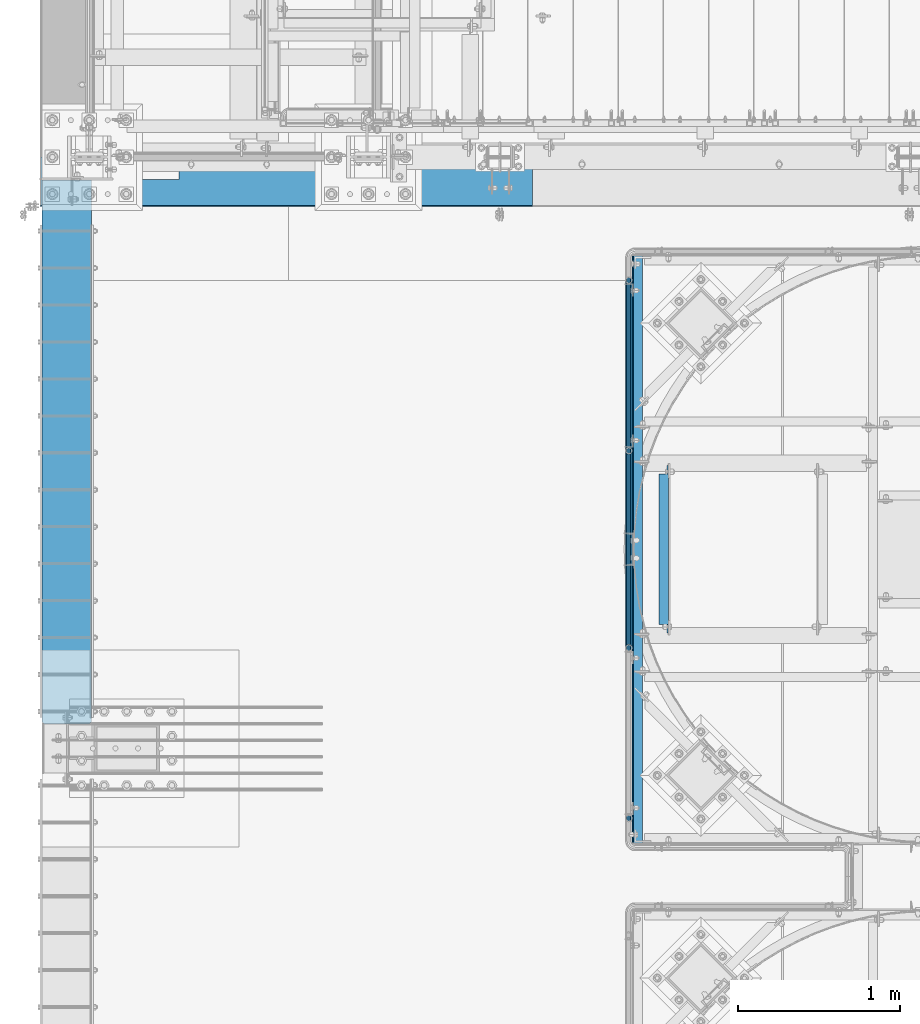
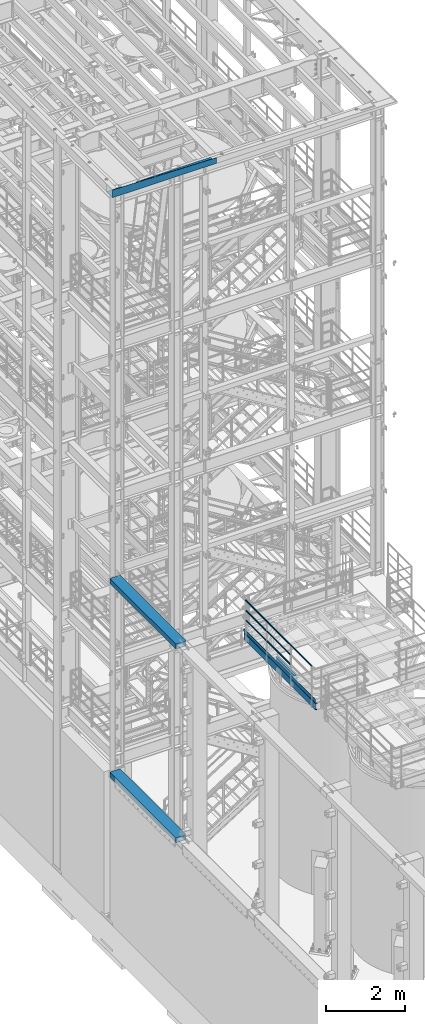
# One storey, part 929 of 1876: 11 beams, 6 elements without a shape of their own.
"""IFC2X3 building model written with IfcOpenShell, lengths in millimetres."""

import ifcopenshell
import ifcopenshell.guid

model = None  # the IFC model being written
_history = None  # IfcOwnerHistory: only IFC2X3 demands one
_inside = {}  # id of a spatial element -> (the spatial element, [elements in it])
_under = {}  # id of a project, library or spatial element -> (it, [spatial elements below it])
_declared = {}  # id of a project -> (the project, [libraries it declares])
_typed = {}  # id of a type object -> (the type object, [elements of that type])
_made_of = {}  # id of a material, layer set ... -> (it, [elements and type objects made of it])


def new_model(schema):
    """Start an empty IFC model of exactly this schema.

    Asked for "IFC4X3", IfcOpenShell would pick the latest addendum, in which some entities
    have other attributes; the version numbers below select the first issue.
    IFC2X3 requires an IfcOwnerHistory on every rooted entity: one is made here for all.
    """
    global model, _history
    if schema == "IFC4X3":
        model = ifcopenshell.file(schema_version=(4, 3, 0, 0))
    else:
        model = ifcopenshell.file(schema=schema)
    _inside.clear()
    _under.clear()
    _declared.clear()
    _typed.clear()
    _made_of.clear()
    _history = None
    if model.schema == "IFC2X3":
        org = make("IfcOrganization", Name="unknown")
        user = make(
            "IfcPersonAndOrganization",
            ThePerson=make("IfcPerson", FamilyName="unknown"),
            TheOrganization=org,
        )
        app = make(
            "IfcApplication",
            ApplicationDeveloper=org,
            Version="unknown",
            ApplicationFullName="unknown",
            ApplicationIdentifier="unknown",
        )
        _history = make(
            "IfcOwnerHistory",
            OwningUser=user,
            OwningApplication=app,
            ChangeAction="ADDED",
            CreationDate=0,
        )
    return model


def make(cls, **values):
    """One entity of the class cls with the attributes given. An attribute that is None is left unset."""
    return model.create_entity(
        cls, **{name: value for name, value in values.items() if value is not None}
    )


def rooted(cls, **values):
    """An entity with a GlobalId (a new one), such as an element, a storey or a relation."""
    return make(cls, GlobalId=ifcopenshell.guid.new(), OwnerHistory=_history, **values)


def si_unit(unit_type, name, prefix=None):
    """IfcSIUnit, for example si_unit("LENGTHUNIT", "METRE", prefix="MILLI")."""
    return make("IfcSIUnit", UnitType=unit_type, Prefix=prefix, Name=name)


def assignment(units):
    """IfcUnitAssignment: the units of a project."""
    return None if units is None else make("IfcUnitAssignment", Units=units)


def point(xyz):
    """IfcCartesianPoint."""
    return None if xyz is None else make("IfcCartesianPoint", Coordinates=xyz)


def direction(xyz):
    """IfcDirection."""
    return None if xyz is None else make("IfcDirection", DirectionRatios=xyz)


def frame(location, z_axis=None, x_axis=None):
    """IfcAxis2Placement3D, a coordinate frame: its origin and axes. An axis left out is left unset."""
    return make(
        "IfcAxis2Placement3D",
        Location=point(location),
        Axis=direction(z_axis),
        RefDirection=direction(x_axis),
    )


def origin_with_axes():
    """The frame at (0, 0, 0) with the z axis (0, 0, 1) and the x axis (1, 0, 0) written out."""
    return frame((0.0, 0.0, 0.0), z_axis=(0.0, 0.0, 1.0), x_axis=(1.0, 0.0, 0.0))


def place(relative_to, where):
    """IfcLocalPlacement: puts the frame where relative to a parent placement (None: the world)."""
    return make(
        "IfcLocalPlacement", PlacementRelTo=relative_to, RelativePlacement=where
    )


def context(
    kind, dimensions, precision=None, world=None, true_north=None, identifier=None
):
    """IfcGeometricRepresentationContext, for example the 3D "Model" context."""
    return make(
        "IfcGeometricRepresentationContext",
        ContextIdentifier=identifier,
        ContextType=kind,
        CoordinateSpaceDimension=dimensions,
        Precision=precision,
        WorldCoordinateSystem=world,
        TrueNorth=true_north,
    )


def subcontext(parent, identifier, kind, view, scale=None):
    """IfcGeometricRepresentationSubContext, for example "Body" below "Model"."""
    return make(
        "IfcGeometricRepresentationSubContext",
        ContextIdentifier=identifier,
        ContextType=kind,
        ParentContext=parent,
        TargetScale=scale,
        TargetView=view,
    )


def project(units=None, contexts=None):
    """IfcProject with its units and contexts."""
    return rooted(
        "IfcProject",
        Name="project",
        RepresentationContexts=contexts,
        UnitsInContext=assignment(units),
    )


def spatial(cls, under=None, at=None, **own):
    """A site, building, storey or space (cls), placed at a placement, below another one or the project."""
    s = rooted(cls, ObjectPlacement=at, **own)
    if under is not None:
        _under.setdefault(under.id(), (under, []))[1].append(s)
    return s


def faces_of(points, faces, orient=None, outer=None):
    """IfcFace entities. A face is a list of loops; a loop is a list of indices into points, from 0.

    orient and outer hold one flag for each loop. By default every Orientation is true, the
    first loop of a face is its IfcFaceOuterBound and the others are IfcFaceBound.
    """
    made = []
    for i, loops in enumerate(faces):
        bounds = []
        for j, loop in enumerate(loops):
            is_outer = j == 0 if outer is None else outer[i][j]
            bounds.append(
                make(
                    "IfcFaceOuterBound" if is_outer else "IfcFaceBound",
                    Bound=make("IfcPolyLoop", Polygon=[points[k] for k in loop]),
                    Orientation=True if orient is None else orient[i][j],
                )
            )
        made.append(make("IfcFace", Bounds=bounds))
    return made


def faceted_brep(points, faces, orient=None, outer=None, voids=None):
    """IfcFacetedBrep: a solid bounded by flat faces; with voids (closed shells), ...WithVoids."""
    shared = [point(p) for p in points]
    hull = make("IfcClosedShell", CfsFaces=faces_of(shared, faces, orient, outer))
    if voids is None:
        return make("IfcFacetedBrep", Outer=hull)
    return make(
        "IfcFacetedBrepWithVoids",
        Outer=hull,
        Voids=[
            make(cls, CfsFaces=faces_of(shared, fs, o, b)) for cls, fs, o, b in voids
        ],
    )


def shape(context_of_items, identifier, shape_type, items):
    """IfcShapeRepresentation: the items that make up one representation, for example the "Body"."""
    return make(
        "IfcShapeRepresentation",
        ContextOfItems=context_of_items,
        RepresentationIdentifier=identifier,
        RepresentationType=shape_type,
        Items=items,
    )


def material(Name=None, Category=None):
    """IfcMaterial."""
    return make("IfcMaterial", Name=Name, Category=Category)


def made_of(thing, what):
    """Note that an element or type object is made of a material, layer set ...; save() writes the relation."""
    if what is not None:
        _made_of.setdefault(what.id(), (what, []))[1].append(thing)
    return thing


def type_object(cls, material=None, **own):
    """A type object (cls), such as IfcWallType, which elements share."""
    return made_of(rooted(cls, **own), material)


def element(
    cls,
    number,
    at=None,
    inside=None,
    cuts=None,
    type_object=None,
    material=None,
    context=None,
    identifier="Body",
    shape_type=None,
    held_by="IfcProductDefinitionShape",
    body=None,
    shapes=None,
    **own,
):
    """One element of the class cls, such as IfcWall. Its Tag is "e" and its number.

    at: its placement. inside: the storey or other place that contains it. cuts: it is an
    opening in that element (IfcRelVoidsElement). A single representation is given by context,
    identifier, shape_type and body (its items); several are given by shapes. held_by: the class
    of the entity that holds the representations. save() writes the other relations.
    """
    e = rooted(cls, Tag="e%d" % number, ObjectPlacement=at, **own)
    if body is not None:
        shapes = [shape(context, identifier, shape_type, body)]
    if shapes is not None:
        e.Representation = make(held_by, Representations=shapes)
    if inside is not None:
        _inside.setdefault(inside.id(), (inside, []))[1].append(e)
    if cuts is not None:
        rooted(
            "IfcRelVoidsElement", RelatingBuildingElement=cuts, RelatedOpeningElement=e
        )
    if type_object is not None:
        _typed.setdefault(type_object.id(), (type_object, []))[1].append(e)
    return made_of(e, material)


def aggregate(whole, parts):
    """IfcRelAggregates: a whole, such as a stair, and the parts it consists of."""
    return rooted("IfcRelAggregates", RelatingObject=whole, RelatedObjects=parts)


def save(model, path):
    """Write the relations noted so far, then the file.

    IfcRelAggregates (storeys below a building ...), IfcRelContainedInSpatialStructure (elements
    in a storey), IfcRelDefinesByType, IfcRelAssociatesMaterial and IfcRelDeclares: one each for
    every whole, place, type object, material and project.
    """
    for whole, parts in _under.values():
        aggregate(whole, parts)
    for where, things in _inside.values():
        rooted(
            "IfcRelContainedInSpatialStructure",
            RelatedElements=things,
            RelatingStructure=where,
        )
    for kind, things in _typed.values():
        rooted("IfcRelDefinesByType", RelatedObjects=things, RelatingType=kind)
    for what, things in _made_of.values():
        rooted("IfcRelAssociatesMaterial", RelatedObjects=things, RelatingMaterial=what)
    for by, libraries in _declared.values():
        rooted("IfcRelDeclares", RelatingContext=by, RelatedDefinitions=libraries)
    model.write(path)


model = new_model("IFC2X3")

# Units and contexts
model_context = context("Model", 3, precision=1e-05, world=origin_with_axes())
body_context = subcontext(model_context, "Body", "Model", "MODEL_VIEW")
ifc_project = project(units=[si_unit("LENGTHUNIT", "METRE", prefix="MILLI"), si_unit("AREAUNIT", "SQUARE_METRE"), si_unit("VOLUMEUNIT", "CUBIC_METRE"), si_unit("MASSUNIT", "GRAM", prefix="KILO"), si_unit("TIMEUNIT", "SECOND"), si_unit("PLANEANGLEUNIT", "RADIAN"), si_unit("SOLIDANGLEUNIT", "STERADIAN"), si_unit("THERMODYNAMICTEMPERATUREUNIT", "DEGREE_CELSIUS"), si_unit("LUMINOUSINTENSITYUNIT", "LUMEN")], contexts=[model_context])

# Site, building, storey
site_placement = place(None, origin_with_axes())
site = spatial("IfcSite", under=ifc_project, at=site_placement, CompositionType="ELEMENT")
building_placement = place(site_placement, origin_with_axes())
building = spatial("IfcBuilding", under=site, at=building_placement, Name="Undefined", CompositionType="ELEMENT")
storey_placement = place(building_placement, origin_with_axes())
storey = spatial("IfcBuildingStorey", under=building, at=storey_placement, Name="Undefined", CompositionType="ELEMENT", Elevation=0.0)

# Assembly, beam
assembly_1_placement = place(storey_placement, origin_with_axes())
assembly_1 = element("IfcElementAssembly", 1, at=assembly_1_placement, inside=storey, Name="BEAM", AssemblyPlace="NOTDEFINED", PredefinedType="RIGID_FRAME")
ifc_material_1 = material()
beam_type_1 = type_object("IfcBeamType", Name="HSS12X6X1/2", PredefinedType="NOTDEFINED")
beam_1_placement = place(assembly_1_placement, frame((-139.700000000001, -10617.2, 10591.8), z_axis=(-1.0, 0.0, 0.0), x_axis=(0.0, 1.0, 0.0)))
beam_1 = element("IfcBeam", 2, at=beam_1_placement, type_object=beam_type_1, material=ifc_material_1, Name="BEAM", ObjectType="HSS12X6X1/2", context=body_context, shape_type="Brep", body=[
    faceted_brep([(3362.325, 63.5, 139.7), (3362.325, -63.5, 139.7), (0.0, -63.5, 139.7), (0.0, 63.5, 139.7), (0.0, -63.5, -139.7), (3362.325, -63.5, -139.7), (0.0, -76.2000000000007, -139.699999999812), (0.0, -76.2000000000007, 139.700000000026), (3362.325, 76.2000000000007, -152.4), (3362.325, -76.2000000000007, -152.4), (12.6998385541701, -76.2000000000007, -152.4), (12.6998385541701, 76.2000000000007, -152.4), (3362.325, -76.2000000000007, 152.4), (12.6999999999734, -76.2000000000007, 152.4), (0.0, 63.5, -139.7), (0.0, 76.2000000000007, -139.699999999812), (3362.325, 63.5, -139.7), (3362.325, 76.2000000000007, 152.4), (0.0, 76.2000000000007, 139.700000000026), (12.6999999999734, 76.2000000000007, 152.4)], [[[0, 1, 2, 3]], [[4, 2, 1, 5]], [[4, 6, 7, 2]], [[8, 9, 10, 11]], [[6, 10, 9, 12, 13, 7]], [[4, 14, 15, 11, 10, 6]], [[5, 16, 14, 4]], [[12, 9, 8, 17], [1, 0, 16, 5]], [[3, 14, 16, 0]], [[15, 14, 3, 18]], [[17, 8, 11, 15, 18, 19]], [[12, 17, 19, 13]], [[18, 3, 2, 7, 13, 19]]]),
])
aggregate(assembly_1, [beam_1])

assembly_2_placement = place(storey_placement, origin_with_axes())
assembly_2 = element("IfcElementAssembly", 3, at=assembly_2_placement, inside=storey, Name="BEAM", AssemblyPlace="NOTDEFINED", PredefinedType="RIGID_FRAME")
beam_2_placement = place(assembly_2_placement, frame((-139.7, -10617.2, 4597.4), z_axis=(-1.0, 0.0, 0.0), x_axis=(0.0, 1.0, 0.0)))
beam_2 = element("IfcBeam", 4, at=beam_2_placement, type_object=beam_type_1, material=ifc_material_1, Name="BEAM", ObjectType="HSS12X6X1/2", context=body_context, shape_type="Brep", body=[
    faceted_brep([(3362.325, 63.5, 139.7), (3362.325, -63.5, 139.7), (0.0, -63.5, 139.7), (0.0, 63.5, 139.7), (0.0, -63.5, -139.7), (3362.325, -63.5, -139.7), (0.0, -76.2000000000007, -139.699999999812), (0.0, -76.2000000000007, 139.700000000026), (3362.325, 76.2000000000007, -152.4), (3362.325, -76.2000000000007, -152.4), (12.6998385541701, -76.2000000000007, -152.4), (12.6998385541701, 76.2000000000007, -152.4), (3362.325, -76.2000000000007, 152.4), (12.6999999999734, -76.2000000000007, 152.4), (0.0, 63.5, -139.7), (0.0, 76.2000000000007, -139.699999999812), (3362.325, 63.5, -139.7), (3362.325, 76.2000000000007, 152.4), (0.0, 76.2000000000007, 139.700000000026), (12.6999999999734, 76.2000000000007, 152.4)], [[[0, 1, 2, 3]], [[4, 2, 1, 5]], [[4, 6, 7, 2]], [[8, 9, 10, 11]], [[6, 10, 9, 12, 13, 7]], [[4, 14, 15, 11, 10, 6]], [[5, 16, 14, 4]], [[12, 9, 8, 17], [1, 0, 16, 5]], [[3, 14, 16, 0]], [[15, 14, 3, 18]], [[17, 8, 11, 15, 18, 19]], [[12, 17, 19, 13]], [[18, 3, 2, 7, 13, 19]]]),
])
aggregate(assembly_2, [beam_2])

# Assembly, beams
assembly_3_placement = place(storey_placement, origin_with_axes())
assembly_3 = element("IfcElementAssembly", 5, at=assembly_3_placement, inside=storey, Name="HANDRAIL", AssemblyPlace="NOTDEFINED", PredefinedType="RIGID_FRAME")
ifc_material_2 = material()
beam_type_2 = type_object("IfcBeamType", Name="PIPE1-1/4STD", PredefinedType="NOTDEFINED")
beam_3_placement = place(assembly_3_placement, frame((3338.07274593762, -8928.06435546873, 8480.425), z_axis=(0.0, 0.0, 1.0), x_axis=(0.0, 1.0, 0.0)))
beam_3 = element("IfcBeam", 6, at=beam_3_placement, type_object=beam_type_2, material=ifc_material_2, Name="RAIL", ObjectType="PIPE1-1/4STD", context=body_context, shape_type="Brep", body=[
    faceted_brep([(1035.84245243742, -10.5409999999993, 18.2575475625836), (1035.84245243742, -10.5409999999993, 13.3999612267253), (1035.36603877327, -8.76300000000083, 15.1779612267255), (1033.018, 0.0, 17.5259999999998), (1033.018, 0.0, 21.0820000000003), (1035.36603877327, 8.76300000000083, 15.1779612267255), (1035.84245243742, 10.5409999999993, 13.3999612267253), (1035.84245243742, 10.5409999999993, 18.2575475625836), (1054.1, 21.0820000000003, 0.0), (1043.559, 18.2575475625836, 10.5409999999993), (1043.559, 18.2575475625836, -10.5409999999993), (1040.47941366414, 15.1779612267255, 8.76300000000083), (1042.82745243742, 17.5259999999998, 0.0), (1040.47941366414, 15.1779612267255, -8.76300000000083), (1035.84245243742, 10.5409999999993, -13.3999612267253), (1035.84245243742, 10.5409999999993, -18.2575475625836), (1035.36603877327, 8.76300000000083, -15.1779612267255), (1033.018, 0.0, -17.5259999999998), (1033.018, 0.0, -21.0820000000003), (1035.84245243742, -10.5409999999993, -13.3999612267253), (1035.84245243742, -10.5409999999993, -18.2575475625836), (1035.36603877327, -8.76300000000083, -15.1779612267255), (1054.1, -21.0820000000003, 0.0), (1043.559, -18.2575475625836, -10.5409999999993), (1043.559, -18.2575475625836, 10.5409999999993), (1040.47941366414, -15.1779612267255, -8.76300000000083), (1042.82745243742, -17.5259999999998, 0.0), (1040.47941366414, -15.1779612267255, 8.76300000000083), (10.5409999957128, -18.2575475672238, -10.5409999999993), (18.2575475625817, -10.5410000000011, -18.2575475625836), (9.09494701772928e-13, 21.0820000000003, 0.0), (10.5409999957128, 18.2575475579433, -10.5409999999993), (10.5409999999983, 18.2575475625836, 10.5410000000011), (18.2575475625817, 10.5409999999993, 18.2575475625836), (21.0819999999985, 1.81898940354586e-12, 21.0820000000003), (18.2575475625817, 10.5409999999993, -18.2575475625836), (21.0819999999985, 0.0, -21.0819999999985), (21.0819999999985, 0.0, -17.5259999999998), (18.2575475625817, -10.5409999999974, -13.3999612267271), (18.7339612267233, -8.76300000000083, -15.1779612267255), (18.7339612267251, 8.76299999999901, -15.1779612267255), (18.2575475625817, 10.5410000000011, -13.3999612267235), (13.6205863358573, 15.1779612267255, -8.76299999999901), (11.2725475625839, 17.5259999999998, 0.0), (13.6205863358573, 15.1779612267255, 8.76300000000083), (18.2575475625817, 10.5410000000011, 13.3999612267253), (18.7339612267251, 8.76299999999901, 15.1779612267273), (21.0819999999985, 1.81898940354586e-12, 17.5259999999998), (18.7339612267233, -8.76300000000083, 15.1779612267273), (18.2575475625817, -10.5409999999974, 13.3999612267289), (18.2575475625817, -10.5410000000011, 18.2575475625836), (10.5409999999983, -18.2575475625836, 10.5410000000011), (9.09494701772928e-13, -21.0820000000003, 0.0), (13.6205863358537, -15.1779612267255, 8.76300000000083), (11.2725475625793, -17.5259999999998, 0.0), (13.6205863358537, -15.1779612267255, -8.76299999999901)], [[[0, 1, 2, 3, 4]], [[4, 3, 5, 6, 7]], [[8, 9, 10]], [[7, 6, 11, 12, 13, 14, 15, 10, 9]], [[16, 17, 18, 15, 14]], [[19, 20, 18, 17, 21]], [[22, 23, 24]], [[24, 23, 20, 19, 25, 26, 27, 1, 0]], [[28, 29, 20, 23]], [[30, 31, 32]], [[33, 34, 4, 7]], [[32, 33, 7, 9]], [[30, 32, 9, 8]], [[31, 30, 8, 10]], [[35, 31, 10, 15]], [[36, 35, 15, 18]], [[29, 36, 18, 20]], [[37, 36, 29, 38, 39]], [[40, 41, 35, 36, 37]], [[32, 31, 35, 41, 42, 43, 44, 45, 33]], [[33, 45, 46, 47, 34]], [[34, 47, 48, 49, 50]], [[34, 50, 0, 4]], [[50, 51, 24, 0]], [[51, 52, 22, 24]], [[52, 28, 23, 22]], [[51, 28, 52]], [[50, 49, 53, 54, 55, 38, 29, 28, 51]], [[55, 54, 26, 25]], [[21, 39, 38, 55, 25, 19]], [[37, 39, 21, 17]], [[40, 37, 17, 16]], [[42, 41, 40, 16, 14, 13]], [[43, 42, 13, 12]], [[44, 43, 12, 11]], [[5, 46, 45, 44, 11, 6]], [[47, 46, 5, 3]], [[48, 47, 3, 2]], [[53, 49, 48, 2, 1, 27]], [[54, 53, 27, 26]]]),
])
beam_4_placement = place(assembly_3_placement, frame((3338.07274593762, -10147.2643554687, 8480.425), z_axis=(0.0, 0.0, 1.0), x_axis=(0.0, 1.0, 0.0)))
beam_4 = element("IfcBeam", 7, at=beam_4_placement, type_object=beam_type_2, material=ifc_material_2, Name="RAIL", ObjectType="PIPE1-1/4STD", context=body_context, shape_type="Brep", body=[
    faceted_brep([(1200.94245243742, -10.5409999999993, 18.2575475625836), (1200.94245243742, -10.5409999999993, 13.3999612267253), (1200.46603877327, -8.76300000000083, 15.1779612267255), (1198.118, 0.0, 17.5259999999998), (1198.118, 0.0, 21.0820000000003), (1200.46603877327, 8.76300000000083, 15.1779612267255), (1200.94245243742, 10.5409999999993, 13.3999612267253), (1200.94245243742, 10.5409999999993, 18.2575475625836), (1219.2, 21.0820000000003, 0.0), (1208.659, 18.2575475625836, 10.5409999999993), (1208.659, 18.2575475625836, -10.5409999999993), (1205.57941366414, 15.1779612267255, 8.76300000000083), (1207.92745243742, 17.5259999999998, 0.0), (1205.57941366414, 15.1779612267255, -8.76300000000083), (1200.94245243742, 10.5409999999993, -13.3999612267253), (1200.94245243742, 10.5409999999993, -18.2575475625836), (1200.46603877327, 8.76300000000083, -15.1779612267255), (1198.118, 0.0, -17.5259999999998), (1198.118, 0.0, -21.0820000000003), (1200.94245243742, -10.5409999999993, -13.3999612267253), (1200.94245243742, -10.5409999999993, -18.2575475625836), (1200.46603877327, -8.76300000000083, -15.1779612267255), (1219.2, -21.0820000000003, 0.0), (1208.659, -18.2575475625836, -10.5409999999993), (1208.659, -18.2575475625836, 10.5409999999993), (1205.57941366414, -15.1779612267255, -8.76300000000083), (1207.92745243742, -17.5259999999998, 0.0), (1205.57941366414, -15.1779612267255, 8.76300000000083), (10.5409999957128, -18.2575475672238, -10.5409999999993), (18.2575475625817, -10.5410000000011, -18.2575475625836), (9.09494701772928e-13, 21.0820000000003, 0.0), (10.5409999957128, 18.2575475579433, -10.5409999999993), (10.5409999999983, 18.2575475625836, 10.5410000000011), (18.2575475625817, 10.5409999999993, 18.2575475625836), (21.0819999999985, 1.81898940354586e-12, 21.0820000000003), (18.2575475625817, 10.5409999999993, -18.2575475625836), (21.0819999999985, 0.0, -21.0819999999985), (21.0819999999985, 0.0, -17.5259999999998), (18.2575475625817, -10.5409999999974, -13.3999612267271), (18.7339612267233, -8.76300000000083, -15.1779612267255), (18.7339612267251, 8.76299999999901, -15.1779612267255), (18.2575475625817, 10.5410000000011, -13.3999612267235), (13.6205863358573, 15.1779612267255, -8.76299999999901), (11.2725475625839, 17.5259999999998, 0.0), (13.6205863358573, 15.1779612267255, 8.76300000000083), (18.2575475625817, 10.5410000000011, 13.3999612267253), (18.7339612267251, 8.76299999999901, 15.1779612267273), (21.0819999999985, 1.81898940354586e-12, 17.5259999999998), (18.7339612267233, -8.76300000000083, 15.1779612267273), (18.2575475625817, -10.5409999999974, 13.3999612267289), (18.2575475625817, -10.5410000000011, 18.2575475625836), (10.5409999999983, -18.2575475625836, 10.5410000000011), (9.09494701772928e-13, -21.0820000000003, 0.0), (13.6205863358537, -15.1779612267255, 8.76300000000083), (11.2725475625793, -17.5259999999998, 0.0), (13.6205863358537, -15.1779612267255, -8.76299999999901)], [[[0, 1, 2, 3, 4]], [[4, 3, 5, 6, 7]], [[8, 9, 10]], [[7, 6, 11, 12, 13, 14, 15, 10, 9]], [[16, 17, 18, 15, 14]], [[19, 20, 18, 17, 21]], [[22, 23, 24]], [[24, 23, 20, 19, 25, 26, 27, 1, 0]], [[28, 29, 20, 23]], [[30, 31, 32]], [[33, 34, 4, 7]], [[32, 33, 7, 9]], [[30, 32, 9, 8]], [[31, 30, 8, 10]], [[35, 31, 10, 15]], [[36, 35, 15, 18]], [[29, 36, 18, 20]], [[37, 36, 29, 38, 39]], [[40, 41, 35, 36, 37]], [[32, 31, 35, 41, 42, 43, 44, 45, 33]], [[33, 45, 46, 47, 34]], [[34, 47, 48, 49, 50]], [[34, 50, 0, 4]], [[50, 51, 24, 0]], [[51, 52, 22, 24]], [[52, 28, 23, 22]], [[51, 28, 52]], [[50, 49, 53, 54, 55, 38, 29, 28, 51]], [[55, 54, 26, 25]], [[21, 39, 38, 55, 25, 19]], [[37, 39, 21, 17]], [[40, 37, 17, 16]], [[42, 41, 40, 16, 14, 13]], [[43, 42, 13, 12]], [[44, 43, 12, 11]], [[5, 46, 45, 44, 11, 6]], [[47, 46, 5, 3]], [[48, 47, 3, 2]], [[53, 49, 48, 2, 1, 27]], [[54, 53, 27, 26]]]),
])
beam_5_placement = place(assembly_3_placement, frame((3338.07274593762, -7873.96435546873, 8785.225), z_axis=(0.0, 0.0, -1.0), x_axis=(0.0, -1.0, 0.0)))
beam_5 = element("IfcBeam", 8, at=beam_5_placement, type_object=beam_type_2, material=ifc_material_2, Name="RAIL", ObjectType="PIPE1-1/4STD", context=body_context, shape_type="Brep", body=[
    faceted_brep([(9.09494701772928e-13, 21.0820000000003, 0.0), (10.5409999957128, 18.2575475579433, -10.5409999999993), (10.5409999999983, 18.2575475625836, 10.5410000000011), (10.5409999999983, -18.2575475625836, 10.5410000000011), (10.5409999957128, -18.2575475672238, -10.5409999999993), (9.09494701772928e-13, -21.0820000000003, 0.0), (18.2575475625817, -10.5410000000011, 18.2575475625836), (18.2575475625817, -10.5409999999974, 13.3999612267289), (13.6205863358537, -15.1779612267255, 8.76300000000083), (11.2725475625793, -17.5259999999998, 0.0), (13.6205863358537, -15.1779612267255, -8.76299999999901), (18.2575475625817, -10.5409999999974, -13.3999612267271), (18.2575475625817, -10.5410000000011, -18.2575475625836), (21.0819999999985, 0.0, -17.5259999999998), (21.0819999999985, 0.0, -21.0819999999985), (18.7339612267233, -8.76300000000083, -15.1779612267255), (18.7339612267251, 8.76299999999901, -15.1779612267255), (18.2575475625817, 10.5410000000011, -13.3999612267235), (18.2575475625817, 10.5409999999993, -18.2575475625836), (13.6205863358573, 15.1779612267255, -8.76299999999901), (11.2725475625839, 17.5259999999998, 0.0), (13.6205863358573, 15.1779612267255, 8.76300000000083), (18.2575475625817, 10.5410000000011, 13.3999612267253), (18.2575475625817, 10.5409999999993, 18.2575475625836), (18.7339612267251, 8.76299999999901, 15.1779612267273), (21.0819999999985, 1.81898940354586e-12, 17.5259999999998), (21.0819999999985, 1.81898940354586e-12, 21.0820000000003), (18.7339612267233, -8.76300000000083, 15.1779612267273), (1054.1, 21.0820000000003, 0.0), (1043.559, 18.2575475625836, -10.5409999999993), (1035.84245243742, 10.5409999999993, -18.2575475625836), (1054.1, -21.0820000000003, 0.0), (1043.559, -18.2575475625836, -10.5409999999993), (1043.559, -18.2575475625836, 10.5409999999993), (1035.84245243742, -10.5409999999993, 18.2575475625836), (1035.84245243742, -10.5409999999993, -18.2575475625836), (1033.018, 0.0, -21.0820000000003), (1035.36603877327, 8.76300000000083, -15.1779612267255), (1033.018, 0.0, -17.5259999999998), (1035.84245243742, 10.5409999999993, -13.3999612267253), (1035.84245243742, -10.5409999999993, -13.3999612267253), (1035.36603877327, -8.76300000000083, -15.1779612267255), (1040.47941366414, -15.1779612267255, -8.76300000000083), (1042.82745243742, -17.5259999999998, 0.0), (1040.47941366414, -15.1779612267255, 8.76300000000083), (1035.84245243742, -10.5409999999993, 13.3999612267253), (1035.36603877327, -8.76300000000083, 15.1779612267255), (1033.018, 0.0, 17.5259999999998), (1033.018, 0.0, 21.0820000000003), (1035.84245243742, 10.5409999999993, 18.2575475625836), (1043.559, 18.2575475625836, 10.5409999999993), (1035.84245243742, 10.5409999999993, 13.3999612267253), (1040.47941366414, 15.1779612267255, 8.76300000000083), (1042.82745243742, 17.5259999999998, 0.0), (1040.47941366414, 15.1779612267255, -8.76300000000083), (1035.36603877327, 8.76300000000083, 15.1779612267255)], [[[0, 1, 2]], [[3, 4, 5]], [[6, 7, 8, 9, 10, 11, 12, 4, 3]], [[13, 14, 12, 11, 15]], [[16, 17, 18, 14, 13]], [[2, 1, 18, 17, 19, 20, 21, 22, 23]], [[23, 22, 24, 25, 26]], [[26, 25, 27, 7, 6]], [[1, 0, 28, 29]], [[18, 1, 29, 30]], [[31, 32, 33]], [[6, 3, 33, 34]], [[3, 5, 31, 33]], [[5, 4, 32, 31]], [[4, 12, 35, 32]], [[12, 14, 36, 35]], [[14, 18, 30, 36]], [[37, 38, 36, 30, 39]], [[40, 35, 36, 38, 41]], [[33, 32, 35, 40, 42, 43, 44, 45, 34]], [[34, 45, 46, 47, 48]], [[26, 6, 34, 48]], [[2, 23, 49, 50]], [[23, 26, 48, 49]], [[0, 2, 50, 28]], [[28, 50, 29]], [[49, 51, 52, 53, 54, 39, 30, 29, 50]], [[48, 47, 55, 51, 49]], [[25, 24, 55, 47]], [[55, 24, 22, 21, 52, 51]], [[21, 20, 53, 52]], [[20, 19, 54, 53]], [[19, 17, 16, 37, 39, 54]], [[16, 13, 38, 37]], [[13, 15, 41, 38]], [[41, 15, 11, 10, 42, 40]], [[10, 9, 43, 42]], [[9, 8, 44, 43]], [[8, 7, 27, 46, 45, 44]], [[27, 25, 47, 46]]]),
])
beam_6_placement = place(assembly_3_placement, frame((3338.07274593762, -8928.06435546873, 8785.225), z_axis=(0.0, 0.0, -1.0), x_axis=(0.0, -1.0, 0.0)))
beam_6 = element("IfcBeam", 9, at=beam_6_placement, type_object=beam_type_2, material=ifc_material_2, Name="RAIL", ObjectType="PIPE1-1/4STD", context=body_context, shape_type="Brep", body=[
    faceted_brep([(9.09494701772928e-13, 21.0820000000003, 0.0), (10.5409999957128, 18.2575475579433, -10.5409999999993), (10.5409999999983, 18.2575475625836, 10.5410000000011), (10.5409999999983, -18.2575475625836, 10.5410000000011), (10.5409999957128, -18.2575475672238, -10.5409999999993), (9.09494701772928e-13, -21.0820000000003, 0.0), (18.2575475625817, -10.5410000000011, 18.2575475625836), (18.2575475625817, -10.5409999999974, 13.3999612267289), (13.6205863358537, -15.1779612267255, 8.76300000000083), (11.2725475625793, -17.5259999999998, 0.0), (13.6205863358537, -15.1779612267255, -8.76299999999901), (18.2575475625817, -10.5409999999974, -13.3999612267271), (18.2575475625817, -10.5410000000011, -18.2575475625836), (21.0819999999985, 0.0, -17.5259999999998), (21.0819999999985, 0.0, -21.0819999999985), (18.7339612267233, -8.76300000000083, -15.1779612267255), (18.7339612267251, 8.76299999999901, -15.1779612267255), (18.2575475625817, 10.5410000000011, -13.3999612267235), (18.2575475625817, 10.5409999999993, -18.2575475625836), (13.6205863358573, 15.1779612267255, -8.76299999999901), (11.2725475625839, 17.5259999999998, 0.0), (13.6205863358573, 15.1779612267255, 8.76300000000083), (18.2575475625817, 10.5410000000011, 13.3999612267253), (18.2575475625817, 10.5409999999993, 18.2575475625836), (18.7339612267251, 8.76299999999901, 15.1779612267273), (21.0819999999985, 1.81898940354586e-12, 17.5259999999998), (21.0819999999985, 1.81898940354586e-12, 21.0820000000003), (18.7339612267233, -8.76300000000083, 15.1779612267273), (1219.2, 21.0820000000003, 0.0), (1208.659, 18.2575475625836, -10.5409999999993), (1200.94245243742, 10.5409999999993, -18.2575475625836), (1219.2, -21.0820000000003, 0.0), (1208.659, -18.2575475625836, -10.5409999999993), (1208.659, -18.2575475625836, 10.5409999999993), (1200.94245243742, -10.5409999999993, 18.2575475625836), (1200.94245243742, -10.5409999999993, -18.2575475625836), (1198.118, 0.0, -21.0820000000003), (1200.46603877327, 8.76300000000083, -15.1779612267255), (1198.118, 0.0, -17.5259999999998), (1200.94245243742, 10.5409999999993, -13.3999612267253), (1200.94245243742, -10.5409999999993, -13.3999612267253), (1200.46603877327, -8.76300000000083, -15.1779612267255), (1205.57941366414, -15.1779612267255, -8.76300000000083), (1207.92745243742, -17.5259999999998, 0.0), (1205.57941366414, -15.1779612267255, 8.76300000000083), (1200.94245243742, -10.5409999999993, 13.3999612267253), (1200.46603877327, -8.76300000000083, 15.1779612267255), (1198.118, 0.0, 17.5259999999998), (1198.118, 0.0, 21.0820000000003), (1200.94245243742, 10.5409999999993, 18.2575475625836), (1208.659, 18.2575475625836, 10.5409999999993), (1200.94245243742, 10.5409999999993, 13.3999612267253), (1205.57941366414, 15.1779612267255, 8.76300000000083), (1207.92745243742, 17.5259999999998, 0.0), (1205.57941366414, 15.1779612267255, -8.76300000000083), (1200.46603877327, 8.76300000000083, 15.1779612267255)], [[[0, 1, 2]], [[3, 4, 5]], [[6, 7, 8, 9, 10, 11, 12, 4, 3]], [[13, 14, 12, 11, 15]], [[16, 17, 18, 14, 13]], [[2, 1, 18, 17, 19, 20, 21, 22, 23]], [[23, 22, 24, 25, 26]], [[26, 25, 27, 7, 6]], [[1, 0, 28, 29]], [[18, 1, 29, 30]], [[31, 32, 33]], [[6, 3, 33, 34]], [[3, 5, 31, 33]], [[5, 4, 32, 31]], [[4, 12, 35, 32]], [[12, 14, 36, 35]], [[14, 18, 30, 36]], [[37, 38, 36, 30, 39]], [[40, 35, 36, 38, 41]], [[33, 32, 35, 40, 42, 43, 44, 45, 34]], [[34, 45, 46, 47, 48]], [[26, 6, 34, 48]], [[2, 23, 49, 50]], [[23, 26, 48, 49]], [[0, 2, 50, 28]], [[28, 50, 29]], [[49, 51, 52, 53, 54, 39, 30, 29, 50]], [[48, 47, 55, 51, 49]], [[25, 24, 55, 47]], [[55, 24, 22, 21, 52, 51]], [[21, 20, 53, 52]], [[20, 19, 54, 53]], [[19, 17, 16, 37, 39, 54]], [[16, 13, 38, 37]], [[13, 15, 41, 38]], [[41, 15, 11, 10, 42, 40]], [[10, 9, 43, 42]], [[9, 8, 44, 43]], [[8, 7, 27, 46, 45, 44]], [[27, 25, 47, 46]]]),
])
beam_7_placement = place(assembly_3_placement, frame((3338.07274593762, -7852.88235546873, 9090.025), z_axis=(0.0, 0.0, -1.0), x_axis=(0.0, -1.0, 0.0)))
beam_7 = element("IfcBeam", 10, at=beam_7_placement, type_object=beam_type_2, material=ifc_material_2, Name="HANDRAIL", ObjectType="PIPE1-1/4STD", context=body_context, shape_type="Brep", body=[
    faceted_brep([(0.0, -17.5259999999998, 0.0), (0.0, -15.1779612267264, 8.76300000000083), (3369.564, -15.177961226726, 8.76300000000083), (3369.564, -17.5259999999998, 0.0), (0.0, -8.76299999999992, 15.1779612267255), (3369.564, -8.76299999999992, 15.1779612267255), (0.0, 0.0, 17.5259999999998), (3369.564, 0.0, 17.5259999999998), (0.0, 8.76299999999992, 15.1779612267255), (3369.564, 8.76299999999992, 15.1779612267255), (0.0, 15.1779612267264, 8.76300000000083), (3369.564, 15.177961226726, 8.76300000000083), (0.0, 17.5259999999998, 0.0), (3369.564, 17.5259999999998, 0.0), (0.0, 15.1779612267264, -8.76300000000083), (3369.564, 15.177961226726, -8.76300000000083), (0.0, 8.76299999999992, -15.1779612267255), (3369.564, 8.76299999999992, -15.1779612267255), (0.0, 0.0, -17.5259999999998), (3369.564, 0.0, -17.5259999999998), (0.0, -8.76299999999992, -15.1779612267255), (3369.564, -8.76299999999992, -15.1779612267255), (0.0, -15.1779612267264, -8.76300000000083), (3369.564, -15.177961226726, -8.76300000000083), (9.09494701772928e-13, -21.0820000000003, 0.0), (0.0, -18.2575475625836, -10.5409999999993), (3369.564, -18.2575475625836, -10.5409999999993), (3369.564, -21.0819999999999, 0.0), (0.0, -10.5410000000002, -18.2575475625836), (3369.564, -10.5410000000002, -18.2575475625836), (-4.28826751885936e-09, 0.0, -21.0820000000003), (3369.564, 0.0, -21.0820000000003), (0.0, 10.5410000000002, -18.2575475625836), (3369.564, 10.5410000000002, -18.2575475625836), (0.0, 18.2575475625836, -10.5409999999993), (3369.564, 18.2575475625836, -10.5409999999993), (9.09494701772928e-13, 21.0820000000003, 0.0), (3369.564, 21.0819999999999, 0.0), (0.0, 18.2575475625836, 10.5409999999993), (3369.564, 18.2575475625836, 10.5409999999993), (0.0, 10.5410000000002, 18.2575475625836), (3369.564, 10.5410000000002, 18.2575475625836), (0.0, 0.0, 21.0820000000003), (3369.564, 0.0, 21.0820000000003), (0.0, -10.5410000000002, 18.2575475625836), (3369.564, -10.5410000000002, 18.2575475625836), (0.0, -18.2575475625836, 10.5409999999993), (3369.564, -18.2575475625836, 10.5409999999993)], [[[0, 1, 2, 3]], [[1, 4, 5, 2]], [[4, 6, 7, 5]], [[6, 8, 9, 7]], [[8, 10, 11, 9]], [[10, 12, 13, 11]], [[12, 14, 15, 13]], [[14, 16, 17, 15]], [[16, 18, 19, 17]], [[18, 20, 21, 19]], [[20, 22, 23, 21]], [[22, 0, 3, 23]], [[24, 25, 26, 27]], [[25, 28, 29, 26]], [[28, 30, 31, 29]], [[30, 32, 33, 31]], [[32, 34, 35, 33]], [[34, 36, 37, 35]], [[36, 38, 39, 37]], [[38, 40, 41, 39]], [[40, 42, 43, 41]], [[42, 44, 45, 43]], [[44, 46, 47, 45]], [[46, 24, 27, 47]], [[29, 31, 33, 35, 37, 39, 41, 43, 45, 47, 27, 26], [5, 7, 9, 11, 13, 15, 17, 19, 21, 23, 3, 2]], [[46, 44, 42, 40, 38, 36, 34, 32, 30, 28, 25, 24], [22, 20, 18, 16, 14, 12, 10, 8, 6, 4, 1, 0]]]),
])
ifc_material_3 = material(Name="STEEL/A36")
beam_type_3 = type_object("IfcBeamType", PredefinedType="NOTDEFINED")
beam_8_placement = place(assembly_3_placement, frame((3362.33306037402, -11353.7643554687, 8080.375), z_axis=(0.0, 0.0, 1.0), x_axis=(0.0, 1.0, 0.0)))
beam_8 = element("IfcBeam", 11, at=beam_8_placement, type_object=beam_type_3, material=ifc_material_3, Name="PLATE", context=body_context, shape_type="Brep", body=[
    faceted_brep([(0.0, 3.17500000000018, -50.8000000000002), (0.0, 3.17500000000018, 50.8000000000002), (3632.1999511731, 3.17500000000018, 50.8000000000002), (3632.1999511731, 3.17500000000018, -50.8000000000002), (0.0, -3.17500000000018, 50.8000000000002), (3632.1999511731, -3.17500000000018, 50.8000000000002), (0.0, -3.17500000000018, -50.8000000000002), (3632.1999511731, -3.17500000000018, -50.8000000000002)], [[[0, 1, 2, 3]], [[1, 4, 5, 2]], [[4, 6, 7, 5]], [[6, 0, 3, 7]], [[5, 7, 3, 2]], [[6, 4, 1, 0]]]),
])
aggregate(assembly_3, [beam_8, beam_3, beam_4, beam_5, beam_6, beam_7])

# Assembly, beam
assembly_4_placement = place(storey_placement, origin_with_axes())
assembly_4 = element("IfcElementAssembly", 12, at=assembly_4_placement, inside=storey, Name="BEAM", AssemblyPlace="NOTDEFINED", PredefinedType="RIGID_FRAME")
beam_type_4 = type_object("IfcBeamType", Name="C8X11.5", PredefinedType="NOTDEFINED")
beam_9_placement = place(assembly_4_placement, frame((3552.82833884985, -10071.0643554687, 7896.225), z_axis=(0.0, 0.0, -1.0), x_axis=(0.0, 1.0, 0.0)))
beam_9 = element("IfcBeam", 13, at=beam_9_placement, type_object=beam_type_4, material=ifc_material_3, Name="BEAM", ObjectType="C8X11.5", context=body_context, shape_type="Brep", body=[
    faceted_brep([(1000.125, -28.5749999999998, -96.8355949999996), (1000.125, -28.5749999999998, -101.6), (1000.125, 28.5749999999998, -101.6), (1000.125, 28.5749999999998, -88.899999809264), (1000.125, 19.0576241940935, -88.899999809264), (1000.22996303464, 22.2250000000004, -88.3723149999996), (1001.09172992259, 28.5749999999998, -84.0399202912186), (1001.09172992259, 22.2250000000004, -84.0399202912186), (1003.84474382307, 28.5749999999998, -79.9197438230649), (1003.84474382307, 22.2250000000004, -79.9197438230649), (1007.96492029122, 28.5749999999998, -77.1667299225865), (1007.96492029122, 22.2250000000004, -77.1667299225865), (1012.82499980927, 28.5749999999998, -76.1999999999989), (1012.82499980927, 22.2250000000004, -76.1999999999989), (1050.925, 22.2250000000004, -76.1999999999989), (1050.925, 28.5749999999998, -76.1999999999989), (1000.125, -28.5749999999998, 101.6), (1000.125, 28.5749999999998, 101.6), (66.6750000000029, 28.5749999999998, 101.6), (66.6750000000029, -28.5749999999998, 101.6), (66.6750000000029, 19.0576241940935, -88.899999809264), (66.6750000000029, 28.5749999999998, -88.899999809264), (66.6750000000029, 28.5749999999998, -101.6), (66.6750000000029, -28.5749999999998, -101.6), (66.6750000000029, -28.5749999999998, -96.8355949999996), (66.5700369653623, 22.2250000000004, -88.3723149999996), (65.7082700774154, 22.2250000000004, -84.0399202912186), (65.7082700774154, 28.5749999999998, -84.0399202912186), (62.9552561769378, 22.2250000000004, -79.9197438230649), (62.9552561769378, 28.5749999999998, -79.9197438230649), (58.8350797087842, 22.2250000000004, -77.1667299225865), (58.8350797087842, 28.5749999999998, -77.1667299225865), (53.9750001907378, 22.2250000000004, -76.1999999999989), (53.9750001907378, 28.5749999999998, -76.1999999999989), (15.875, 22.2250000000004, -76.1999999999989), (15.875, 28.5749999999998, -76.1999999999989), (15.875, 22.2250000000004, 76.2000000000007), (15.875, 28.5749999999998, 76.2000000000007), (53.9750001907378, 22.2250000000004, 76.2000000000007), (53.9750001907378, 28.5749999999998, 76.2000000000007), (58.8350797087842, 22.2250000000004, 77.1667299225883), (58.8350797087842, 28.5749999999998, 77.1667299225883), (62.9552561769378, 22.2250000000004, 79.9197438230667), (62.9552561769378, 28.5749999999998, 79.9197438230667), (65.7082700774154, 22.2250000000004, 84.0399202912204), (65.7082700774154, 28.5749999999998, 84.0399202912204), (66.6750000000029, 19.0576241940826, 88.8999998092659), (66.6750000000029, 28.5749999999998, 88.8999998092659), (66.5700369653623, 22.2250000000004, 88.3723149999996), (66.6750000000029, -28.5749999999998, 96.8355949999996), (1000.125, -28.5749999999998, 96.8355949999996), (1000.125, 19.0576241940826, 88.8999998092659), (1000.125, 28.5749999999998, 88.8999998092659), (1000.22996303464, 22.2250000000004, 88.3723149999996), (1001.09172992259, 22.2250000000004, 84.0399202912204), (1001.09172992259, 28.5749999999998, 84.0399202912204), (1003.84474382307, 22.2250000000004, 79.9197438230667), (1003.84474382307, 28.5749999999998, 79.9197438230667), (1007.96492029122, 22.2250000000004, 77.1667299225883), (1007.96492029122, 28.5749999999998, 77.1667299225883), (1012.82499980927, 22.2250000000004, 76.2000000000007), (1012.82499980927, 28.5749999999998, 76.2000000000007), (1050.925, 22.2250000000004, 76.2000000000007), (1050.925, 28.5749999999998, 76.2000000000007)], [[[0, 1, 2, 3, 4]], [[5, 4, 3, 6, 7]], [[7, 6, 8, 9]], [[9, 8, 10, 11]], [[11, 10, 12, 13]], [[14, 13, 12, 15]], [[16, 17, 18, 19]], [[20, 21, 22, 23, 24]], [[25, 26, 27, 21, 20]], [[28, 29, 27, 26]], [[30, 31, 29, 28]], [[32, 33, 31, 30]], [[34, 35, 33, 32]], [[36, 37, 35, 34]], [[38, 39, 37, 36]], [[40, 41, 39, 38]], [[42, 43, 41, 40]], [[44, 45, 43, 42]], [[46, 47, 45, 44, 48]], [[19, 18, 47, 46, 49]], [[50, 16, 19, 49]], [[16, 50, 51, 52, 17]], [[48, 53, 51, 50, 49, 46]], [[54, 55, 52, 51, 53]], [[56, 57, 55, 54]], [[58, 59, 57, 56]], [[60, 61, 59, 58]], [[62, 63, 61, 60]], [[63, 62, 14, 15]], [[29, 31, 33, 35, 37, 39, 41, 43, 45, 47, 18, 17, 52, 55, 57, 59, 61, 63, 15, 12, 10, 8, 6, 3, 2, 22, 21, 27]], [[2, 1, 23, 22]], [[1, 0, 24, 23]], [[24, 0, 4, 5, 25, 20]], [[5, 7, 9, 11, 13, 14, 62, 60, 58, 56, 54, 53, 48, 44, 42, 40, 38, 36, 34, 32, 30, 28, 26, 25]]]),
])
aggregate(assembly_4, [beam_9])

assembly_5_placement = place(storey_placement, origin_with_axes())
assembly_5 = element("IfcElementAssembly", 14, at=assembly_5_placement, inside=storey, Name="BEAM", AssemblyPlace="NOTDEFINED", PredefinedType="RIGID_FRAME")
beam_10_placement = place(assembly_5_placement, frame((3394.07833884985, -11353.7643554687, 7896.225), z_axis=(0.0, 0.0, 1.0), x_axis=(0.0, 1.0, 0.0)))
beam_10 = element("IfcBeam", 15, at=beam_10_placement, type_object=beam_type_4, material=ifc_material_3, Name="BEAM", ObjectType="C8X11.5", context=body_context, shape_type="Brep", body=[
    faceted_brep([(0.0, 28.5749999999998, -101.6), (0.0, 28.5749999999998, 101.6), (3632.1999511731, 28.5749999999998, 101.6), (3632.1999511731, 28.5749999999998, -101.6), (0.0, -28.5749999999998, 101.6), (3632.1999511731, -28.5749999999998, 101.6), (0.0, -28.5749999999998, 96.8355950000005), (3632.1999511731, -28.5749999999998, 96.8355949999996), (0.0, 22.2250000000004, 88.3723150000005), (3632.1999511731, 22.2250000000004, 88.3723149999996), (0.0, 22.2250000000004, -88.3723150000005), (3632.1999511731, 22.2250000000004, -88.3723149999996), (0.0, -28.5749999999998, -96.8355950000005), (3632.1999511731, -28.5749999999998, -96.8355949999996), (0.0, -28.5749999999998, -101.6), (3632.1999511731, -28.5749999999998, -101.6)], [[[0, 1, 2, 3]], [[1, 4, 5, 2]], [[4, 6, 7, 5]], [[6, 8, 9, 7]], [[8, 10, 11, 9]], [[10, 12, 13, 11]], [[12, 14, 15, 13]], [[14, 0, 3, 15]], [[5, 7, 9, 11, 13, 15, 3, 2]], [[14, 12, 10, 8, 6, 4, 1, 0]]]),
])
aggregate(assembly_5, [beam_10])

assembly_6_placement = place(storey_placement, origin_with_axes())
assembly_6 = element("IfcElementAssembly", 16, at=assembly_6_placement, inside=storey, Name="BENT PLATE", AssemblyPlace="NOTDEFINED", PredefinedType="RIGID_FRAME")
beam_type_5 = type_object("IfcBeamType", PredefinedType="NOTDEFINED")
beam_11_placement = place(assembly_6_placement, frame((1219.2, -7111.99997714219, 22558.3750000001), z_axis=(1.0, 0.0, 0.0), x_axis=(0.0, -0.999999999968684, -7.91400000071008e-06)))
beam_11 = element("IfcBeam", 17, at=beam_11_placement, type_object=beam_type_5, material=ifc_material_3, Name="BENT PLATE", context=body_context, shape_type="Brep", body=[
    faceted_brep([(139.699996952975, -3.1749999565327, -1084.26250610352), (139.700042666625, 3.17500004346948, -1084.26250610352), (-9.88620740827173e-10, 3.17500000000291, -1084.26250610352), (9.877112461254e-10, -3.17499999999563, -1084.26250610352), (139.699996952975, -3.1749999565327, -665.1625), (139.700042666625, 3.17500004346948, -665.1625), (9.877112461254e-10, -3.17499999999563, -665.1625), (-9.88620740827173e-10, 3.17500000000291, -665.1625), (304.799984389461, 3.1750000948341, -1524.0), (304.799984389461, 3.1750000948341, 1524.0), (304.798968570619, -173.68010041623, 1524.0), (304.798604036543, -236.934982372877, -1524.0), (298.449951181137, -3.17499990713986, 1524.0), (298.449951181137, -3.17499990713986, -1524.0), (298.448604036646, -236.934945778205, -1524.0), (298.448968570774, -173.680054702581, 1524.0), (-9.88620740827173e-10, 3.17500000000291, 1524.0), (9.877112461254e-10, -3.17499999999563, 1524.0), (9.877112461254e-10, -3.17499999999563, -1524.0), (-9.88620740827173e-10, 3.17500000000291, -1524.0)], [[[0, 1, 2, 3]], [[4, 5, 1, 0]], [[6, 7, 5, 4]], [[8, 9, 10, 11]], [[12, 13, 14, 15]], [[9, 16, 17, 12, 15, 10]], [[14, 11, 10, 15]], [[13, 18, 19, 8, 11, 14]], [[19, 18, 3, 2]], [[16, 9, 8, 19, 2, 1, 5, 7]], [[17, 16, 7, 6]], [[3, 18, 13, 12, 17, 6, 4, 0]]]),
])
aggregate(assembly_6, [beam_11])

save(model, "model.ifc")
